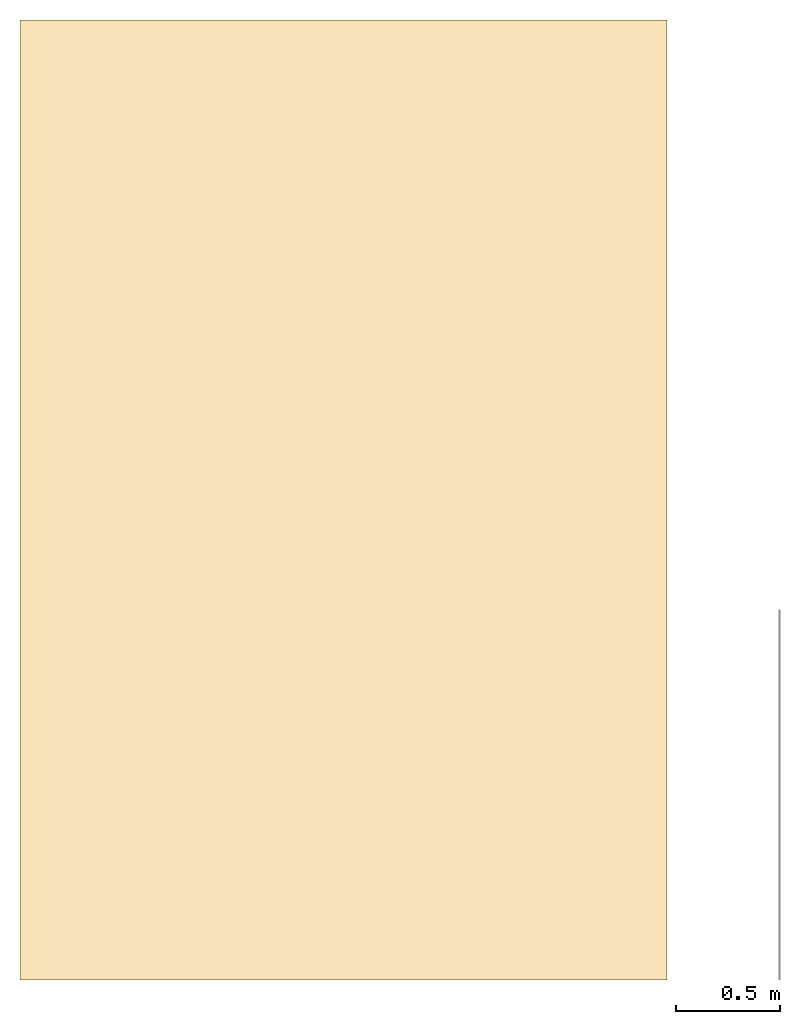
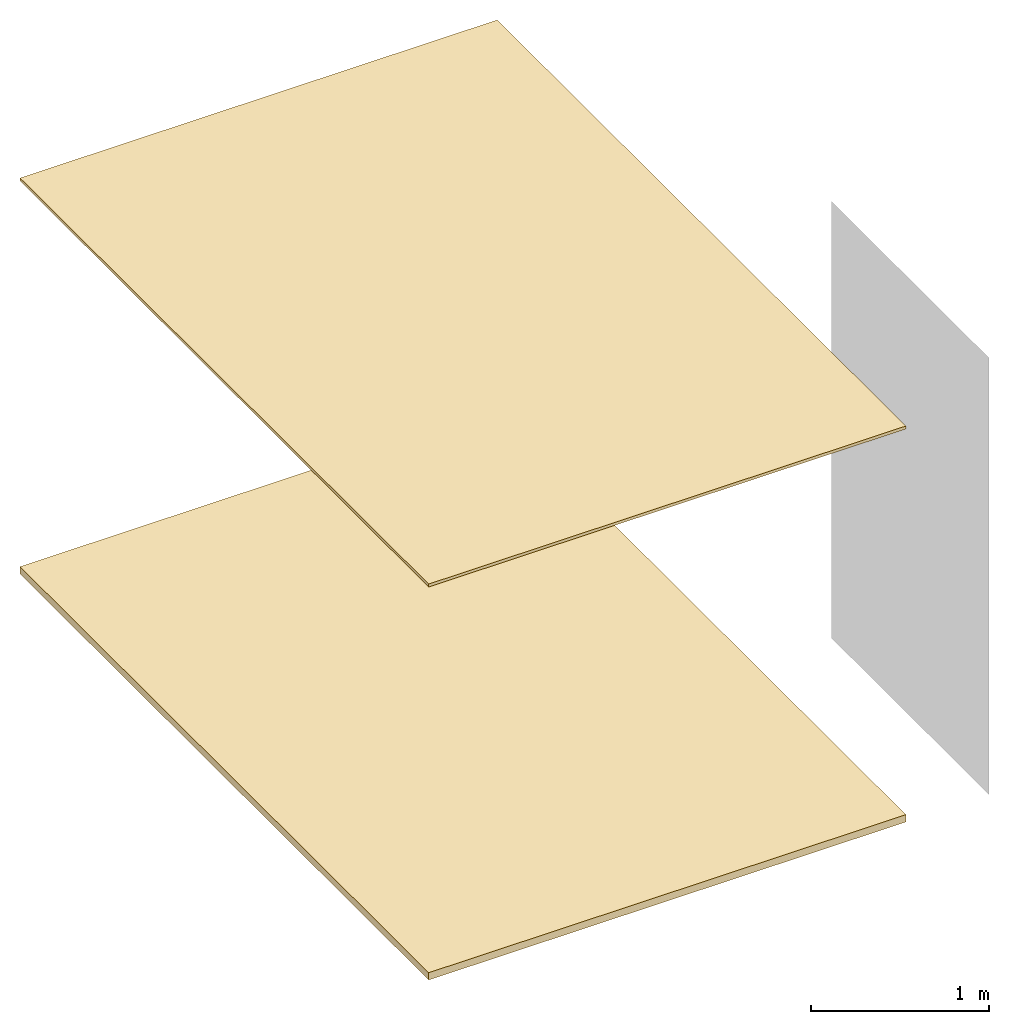
# Not in any storey, part 1 of 2: 6 coverings.
"""IFC4 model written with IfcOpenShell, lengths in metres."""

from ifc_helpers import new_model, entity, si_unit, converted_unit, frame, origin_with_axes, origin_2d_with_axis, place, context, subcontext, project, line, indexed_curve, outline, extrude, material, layer, layer_set, layer_usage, type_object, element, save


model = new_model("IFC4")

# Units and contexts
model_context = context("Model", 3, precision=1e-05, world=origin_with_axes())
plan_context = context("Plan", 2, precision=1e-05, world=origin_2d_with_axis())
body_context = subcontext(model_context, "Body", "Model", "MODEL_VIEW")
ifc_project = project(units=[si_unit("VOLUMEUNIT", "CUBIC_METRE"), si_unit("LENGTHUNIT", "METRE"), converted_unit("PLANEANGLEUNIT", "degree", entity("IfcReal", 0.0174532925199433), si_unit("PLANEANGLEUNIT", "RADIAN"), dimensions=[0, 0, 0, 0, 0, 0, 0]), si_unit("AREAUNIT", "SQUARE_METRE")], contexts=[model_context, plan_context])

# Coverings
ifc_material = material()
ifc_layer_1 = layer(ifc_material, 0.0500000007450581)
ifc_layer_set_1 = layer_set([ifc_layer_1])
ifc_layer_usage_1 = layer_usage(ifc_layer_set_1, "AXIS3", "POSITIVE", 0.0)
covering_type_1 = type_object("IfcCoveringType", Name="FLR-01", PredefinedType="FLOORING", material=ifc_layer_set_1)
covering_1_placement = place(None, frame((0.200001418590546, 0.200000286102295, 0.0), z_axis=(0.0, 0.0, 1.0), x_axis=(1.0, 0.0, 0.0)))
element("IfcCovering", 1, at=covering_1_placement, type_object=covering_type_1, material=ifc_layer_usage_1, Name="FLOOR", context=body_context, shape_type="SweptSolid", body=[
    extrude(outline(indexed_curve([(0.0, 0.0), (3.10065174102783, 0.0), (3.10065174102783, 4.60000133514404), (0.0, 4.60000133514404)], segments=[line(3, 2), line(2, 1), line(1, 4), line(4, 3)], self_intersect=False)), None, (0.0, 0.0, 1.0), 0.0500000007450581),
])
ifc_layer_usage_2 = layer_usage(ifc_layer_set_1, "AXIS3", "POSITIVE", 0.0)
covering_2_placement = place(None, frame((0.200001433491707, 0.200002193450928, 0.0), z_axis=(0.0, 0.0, 1.0), x_axis=(1.0, 0.0, 0.0)))
element("IfcCovering", 2, at=covering_2_placement, type_object=covering_type_1, material=ifc_layer_usage_2, Name="FLOOR.001", PredefinedType="FLOORING", context=body_context, shape_type="SweptSolid", body=[
    extrude(outline(indexed_curve([(0.0, 0.0), (3.10065174102783, 0.0), (3.10065174102783, 4.59999942779541), (0.0, 4.59999942779541)], segments=[line(4, 1), line(1, 2), line(2, 3), line(3, 4)], self_intersect=False)), None, (0.0, 0.0, 1.0), 0.0500000007450581),
])
ifc_layer_usage_3 = layer_usage(ifc_layer_set_1, "AXIS3", "POSITIVE", 0.0)
covering_3_placement = place(None, frame((0.200000137090683, 0.200002193450928, 0.0), z_axis=(0.0, 0.0, 1.0), x_axis=(1.0, 0.0, 0.0)))
element("IfcCovering", 3, at=covering_3_placement, type_object=covering_type_1, material=ifc_layer_usage_3, Name="floor", PredefinedType="FLOORING", context=body_context, shape_type="SweptSolid", body=[
    extrude(outline(indexed_curve([(0.0, 0.0), (3.10065317153931, 0.0), (3.10065317153931, 4.59999942779541), (0.0, 4.59999942779541)], segments=[line(3, 2), line(2, 1), line(1, 4), line(4, 3)], self_intersect=False)), None, (0.0, 0.0, 1.0), 0.0500000007450581),
])
ifc_layer_2 = layer(ifc_material, 0.0199999995529652)
ifc_layer_set_2 = layer_set([ifc_layer_2])
ifc_layer_usage_4 = layer_usage(ifc_layer_set_2, "AXIS3", "POSITIVE", 0.0)
covering_type_2 = type_object("IfcCoveringType", Name="CEL-01", PredefinedType="CEILING", material=ifc_layer_set_2)
covering_4_placement = place(None, frame((0.200001433491707, 0.200002193450928, 2.70000004768372), z_axis=(0.0, 0.0, 1.0), x_axis=(1.0, 0.0, 0.0)))
element("IfcCovering", 4, at=covering_4_placement, type_object=covering_type_2, material=ifc_layer_usage_4, Name="Ceiling", context=body_context, shape_type="SweptSolid", body=[
    extrude(outline(indexed_curve([(0.0, 0.0), (3.10065174102783, 0.0), (3.10065174102783, 4.59999942779541), (0.0, 4.59999942779541)], segments=[line(4, 1), line(1, 2), line(2, 3), line(3, 4)], self_intersect=False)), None, (0.0, 0.0, 1.0), 0.0199999995529652),
])
ifc_layer_usage_5 = layer_usage(ifc_layer_set_2, "AXIS3", "POSITIVE", 0.0)
covering_5_placement = place(None, frame((0.200000166893005, 0.200000047683716, 2.70000004768372), z_axis=(0.0, 0.0, 1.0), x_axis=(1.0, 0.0, 0.0)))
element("IfcCovering", 5, at=covering_5_placement, type_object=covering_type_2, material=ifc_layer_usage_5, Name="Covering", context=body_context, shape_type="SweptSolid", body=[
    extrude(outline(indexed_curve([(0.0, 0.0), (3.10065317153931, 0.0), (3.10065317153931, 4.60000133514404), (0.0, 4.60000133514404)], segments=[line(3, 2), line(2, 1), line(1, 4), line(4, 3)], self_intersect=False)), None, (0.0, 0.0, 1.0), 0.0199999995529652),
])
ifc_layer_usage_6 = layer_usage(ifc_layer_set_2, "AXIS3", "POSITIVE", 0.0)
covering_6_placement = place(None, frame((0.200000166893005, 0.200002193450928, 2.70000004768372), z_axis=(0.0, 0.0, 1.0), x_axis=(1.0, 0.0, 0.0)))
element("IfcCovering", 6, at=covering_6_placement, type_object=covering_type_2, material=ifc_layer_usage_6, Name="ceiling", context=body_context, shape_type="SweptSolid", body=[
    extrude(outline(indexed_curve([(0.0, 0.0), (3.10065317153931, 0.0), (3.10065317153931, 4.59999942779541), (0.0, 4.59999942779541)], segments=[line(4, 1), line(1, 2), line(2, 3), line(3, 4)], self_intersect=False)), None, (0.0, 0.0, 1.0), 0.0199999995529652),
])

save(model, "model.ifc")
